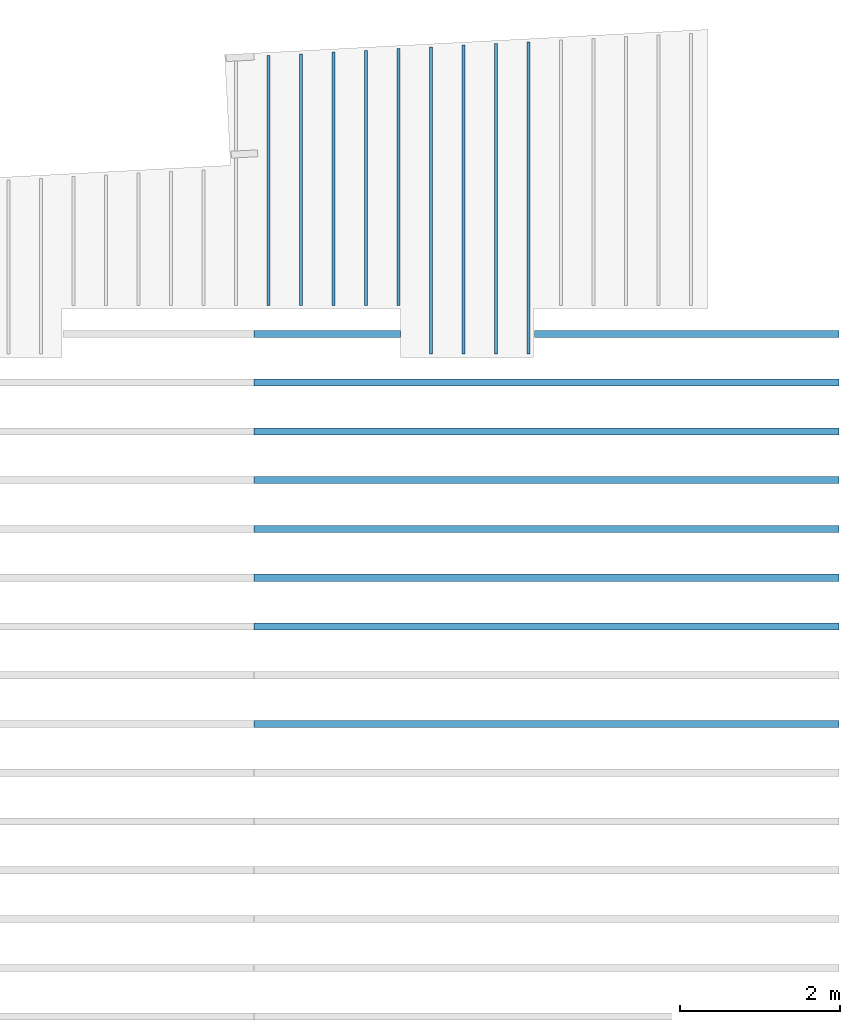
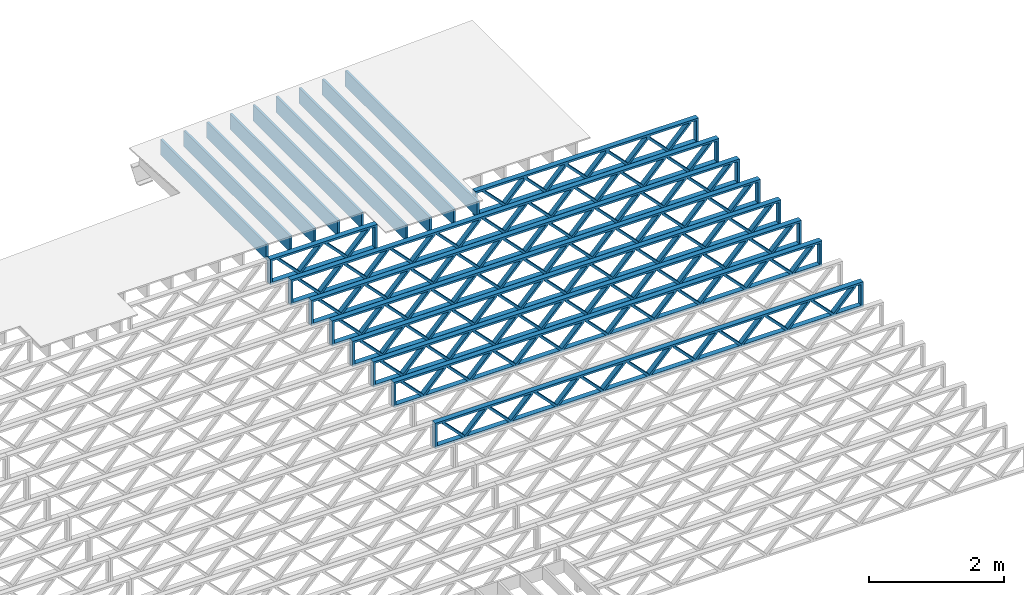
# One storey, part 11 of 12: 18 beams, 2 elements without a shape of their own.
"""IFC4 building model written with IfcOpenShell, lengths in feet."""

from ifc_helpers import new_model, entity, si_unit, converted_unit, derived_unit, direction, frame, frame_2d, origin, origin_2d_with_axis, place, context, subcontext, project, spatial, rectangle, extrude, source, transform, mapped, material, material_profile, profile_set, profile_usage, type_object, type_shapes, element, aggregate, save


model = new_model("IFC4")

# Units and contexts
model_context = context("Model", 3, precision=0.0001, world=origin(), true_north=direction((6.12303176911189e-17, 1.0)))
body_context = subcontext(model_context, "Body", "Model", "MODEL_VIEW")
ifc_project = project(units=[converted_unit("LENGTHUNIT", "FOOT", entity("IfcRatioMeasure", 0.3048), si_unit("LENGTHUNIT", "METRE"), dimensions=[1, 0, 0, 0, 0, 0, 0]), converted_unit("AREAUNIT", "SQUARE FOOT", entity("IfcRatioMeasure", 0.09290304), si_unit("AREAUNIT", "SQUARE_METRE"), dimensions=[2, 0, 0, 0, 0, 0, 0]), converted_unit("VOLUMEUNIT", "CUBIC FOOT", entity("IfcRatioMeasure", 0.028316846592), si_unit("VOLUMEUNIT", "CUBIC_METRE"), dimensions=[3, 0, 0, 0, 0, 0, 0]), converted_unit("PLANEANGLEUNIT", "DEGREE", entity("IfcRatioMeasure", 0.0174532925199433), si_unit("PLANEANGLEUNIT", "RADIAN"), dimensions=[0, 0, 0, 0, 0, 0, 0]), si_unit("MASSUNIT", "GRAM", prefix="KILO"), derived_unit("MASSDENSITYUNIT", [(si_unit("MASSUNIT", "GRAM", prefix="KILO"), 1), (si_unit("LENGTHUNIT", "METRE"), -3)]), derived_unit("MOMENTOFINERTIAUNIT", [(si_unit("LENGTHUNIT", "METRE"), 4)]), si_unit("TIMEUNIT", "SECOND"), si_unit("FREQUENCYUNIT", "HERTZ"), si_unit("THERMODYNAMICTEMPERATUREUNIT", "DEGREE_CELSIUS"), derived_unit("THERMALTRANSMITTANCEUNIT", [(si_unit("MASSUNIT", "GRAM", prefix="KILO"), 1), (si_unit("THERMODYNAMICTEMPERATUREUNIT", "KELVIN"), -1), (si_unit("TIMEUNIT", "SECOND"), -3)]), derived_unit("VOLUMETRICFLOWRATEUNIT", [(si_unit("LENGTHUNIT", "METRE"), 3), (si_unit("TIMEUNIT", "SECOND"), -1)]), si_unit("ELECTRICCURRENTUNIT", "AMPERE"), si_unit("ELECTRICVOLTAGEUNIT", "VOLT"), si_unit("POWERUNIT", "WATT"), si_unit("FORCEUNIT", "NEWTON"), si_unit("ILLUMINANCEUNIT", "LUX"), si_unit("LUMINOUSFLUXUNIT", "LUMEN"), si_unit("LUMINOUSINTENSITYUNIT", "CANDELA"), derived_unit("USERDEFINED", [(si_unit("MASSUNIT", "GRAM", prefix="KILO"), -1), (si_unit("LENGTHUNIT", "METRE"), -2), (si_unit("TIMEUNIT", "SECOND"), 3), (si_unit("LUMINOUSFLUXUNIT", "LUMEN"), 1)]), derived_unit("LINEARVELOCITYUNIT", [(si_unit("LENGTHUNIT", "METRE"), 1), (si_unit("TIMEUNIT", "SECOND"), -1)]), si_unit("PRESSUREUNIT", "PASCAL"), derived_unit("USERDEFINED", [(si_unit("LENGTHUNIT", "METRE"), -2), (si_unit("MASSUNIT", "GRAM", prefix="KILO"), 1), (si_unit("TIMEUNIT", "SECOND"), -2)]), derived_unit("LINEARFORCEUNIT", [(si_unit("MASSUNIT", "GRAM", prefix="KILO"), 1), (si_unit("LENGTHUNIT", "METRE"), 1), (si_unit("TIMEUNIT", "SECOND"), -2), (si_unit("LENGTHUNIT", "METRE"), -1)]), derived_unit("PLANARFORCEUNIT", [(si_unit("MASSUNIT", "GRAM", prefix="KILO"), 1), (si_unit("LENGTHUNIT", "METRE"), 1), (si_unit("TIMEUNIT", "SECOND"), -2), (si_unit("LENGTHUNIT", "METRE"), -2)])], contexts=[model_context])

# Site, building, storey
site_placement = place(None, origin())
site = spatial("IfcSite", under=ifc_project, at=site_placement, CompositionType="ELEMENT")
building_placement = place(site_placement, origin())
building = spatial("IfcBuilding", under=site, at=building_placement, CompositionType="ELEMENT")
storey_placement = place(building_placement, frame((0.0, 0.0, 21.46875)))
storey = spatial("IfcBuildingStorey", under=building, at=storey_placement, Name="3RD FLOOR", CompositionType="ELEMENT", Elevation=21.46875)

# Assembly, beams
assembly_1_placement = place(storey_placement, origin())
assembly_1 = element("IfcElementAssembly", 1, at=assembly_1_placement, inside=storey, Name="Structural Beam System:Structural Framing System", ObjectType="Structural Beam System:Structural Framing System", AssemblyPlace="NOTDEFINED", PredefinedType="BEAM_GRID")
ifc_material_1 = material(Name="WOOD TRUSS", Category="Materials")
ifc_material_profile_1 = material_profile(ifc_material_1, rectangle(XDim=1.73473973950632, YDim=0.125, at=frame_2d((-1.11022302462516e-16, 8.32667268468867e-17), x_axis=(1.0, 0.0))))
ifc_material_profile_2 = material_profile(ifc_material_1, rectangle(XDim=1.73473973950633, YDim=0.125, at=frame_2d((-1.11022302462516e-16, 8.32667268468867e-17), x_axis=(1.0, 0.0))))
ifc_material_profile_3 = material_profile(ifc_material_1, rectangle(XDim=1.73473973950632, YDim=0.125, at=frame_2d((-5.55111512312578e-17, 1.38777878078145e-16), x_axis=(1.0, 0.0))))
ifc_material_profile_4 = material_profile(ifc_material_1, rectangle(XDim=1.73473973950633, YDim=0.125, at=frame_2d((-1.11022302462516e-16, 8.32667268468867e-17), x_axis=(1.0, 0.0))))
ifc_material_profile_5 = material_profile(ifc_material_1, rectangle(XDim=1.73473973950632, YDim=0.125, at=frame_2d((-1.11022302462516e-16, 8.32667268468867e-17), x_axis=(1.0, 0.0))))
ifc_material_profile_6 = material_profile(ifc_material_1, rectangle(XDim=1.73473973950633, YDim=0.125, at=frame_2d((-2.77555756156289e-16, 3.05311331771918e-16), x_axis=(1.0, 0.0))))
ifc_material_profile_7 = material_profile(ifc_material_1, rectangle(XDim=1.73473973950632, YDim=0.124999999999999, at=frame_2d((-3.88578058618805e-16, -2.4980018054066e-16), x_axis=(1.0, 0.0))))
ifc_material_profile_8 = material_profile(ifc_material_1, rectangle(XDim=1.73473973950633, YDim=0.125, at=frame_2d((2.77555756156289e-16, -3.05311331771918e-16), x_axis=(1.0, 0.0))))
ifc_material_profile_9 = material_profile(ifc_material_1, rectangle(XDim=1.73473973950632, YDim=0.124999999999999, at=frame_2d((-1.11022302462516e-16, 8.32667268468867e-17), x_axis=(1.0, 0.0))))
ifc_material_profile_10 = material_profile(ifc_material_1, rectangle(XDim=1.73473973950633, YDim=0.125, at=origin_2d_with_axis()))
ifc_material_profile_11 = material_profile(ifc_material_1, rectangle(XDim=0.124999999999982, YDim=0.291666666666668, at=origin_2d_with_axis()))
ifc_material_profile_12 = material_profile(ifc_material_1, rectangle(XDim=0.124999999999932, YDim=0.291666666666664, at=origin_2d_with_axis()))
ifc_material_profile_13 = material_profile(ifc_material_1, rectangle(XDim=1.25000000000002, YDim=0.29166666666667, at=origin_2d_with_axis()))
ifc_material_profile_14 = material_profile(ifc_material_1, rectangle(XDim=1.25000000000004, YDim=0.291666666666667, at=origin_2d_with_axis()))
ifc_profile_set_1 = profile_set([ifc_material_profile_1, ifc_material_profile_2, ifc_material_profile_3, ifc_material_profile_4, ifc_material_profile_5, ifc_material_profile_6, ifc_material_profile_7, ifc_material_profile_8, ifc_material_profile_9, ifc_material_profile_10, ifc_material_profile_11, ifc_material_profile_12, ifc_material_profile_13, ifc_material_profile_14])
ifc_profile_usage_1 = profile_usage(ifc_profile_set_1, cardinal=8)
beam_type_1 = type_object("IfcBeamType", PredefinedType="BEAM", material=ifc_profile_set_1)
shared_shape_1 = source(origin(), body_context, "Body", "SweptSolid", [
    extrude(rectangle(XDim=1.73473973950632, YDim=0.125, at=frame_2d((-1.11022302462516e-16, 8.32667268468867e-17), x_axis=(1.0, 0.0))), frame((2.91681155651982, -0.145833333333334, 0.0), z_axis=(0.0, 1.0, 0.0), x_axis=(0.693383046997606, 0.0, 0.720569184836762)), (0.0, 0.0, 1.0), 0.291666666666667),
    extrude(rectangle(XDim=1.73473973950633, YDim=0.125, at=frame_2d((-1.11022302462516e-16, 8.32667268468867e-17), x_axis=(1.0, 0.0))), frame((1.66652568284655, -0.145833333333334, 0.0), z_axis=(0.0, 1.0, 0.0), x_axis=(0.69338304699761, 0.0, -0.720569184836758)), (0.0, 0.0, 1.0), 0.291666666666667),
    extrude(rectangle(XDim=1.73473973950632, YDim=0.125, at=frame_2d((-5.55111512312578e-17, 1.38777878078145e-16), x_axis=(1.0, 0.0))), frame((0.625142936836964, -0.145833333333334, 0.0), z_axis=(0.0, 1.0, 0.0), x_axis=(0.693383046997606, 0.0, 0.720569184836762)), (0.0, 0.0, 1.0), 0.291666666666667),
    extrude(rectangle(XDim=1.73473973950633, YDim=0.125, at=frame_2d((-1.11022302462516e-16, 8.32667268468867e-17), x_axis=(1.0, 0.0))), frame((-0.625142936836307, -0.145833333333334, 0.0), z_axis=(0.0, 1.0, 0.0), x_axis=(0.69338304699761, 0.0, -0.720569184836758)), (0.0, 0.0, 1.0), 0.291666666666667),
    extrude(rectangle(XDim=1.73473973950632, YDim=0.125, at=frame_2d((-1.11022302462516e-16, 8.32667268468867e-17), x_axis=(1.0, 0.0))), frame((-1.66652568284589, -0.145833333333334, 0.0), z_axis=(0.0, 1.0, 0.0), x_axis=(0.693383046997606, 0.0, 0.720569184836762)), (0.0, 0.0, 1.0), 0.291666666666667),
    extrude(rectangle(XDim=1.73473973950633, YDim=0.125, at=frame_2d((-2.77555756156289e-16, 3.05311331771918e-16), x_axis=(1.0, 0.0))), frame((-2.91681155651916, -0.145833333333334, 0.0), z_axis=(0.0, 1.0, 0.0), x_axis=(0.69338304699761, 0.0, -0.720569184836758)), (0.0, 0.0, 1.0), 0.291666666666667),
    extrude(rectangle(XDim=1.73473973950632, YDim=0.124999999999999, at=frame_2d((-3.88578058618805e-16, -2.4980018054066e-16), x_axis=(1.0, 0.0))), frame((5.20848017620267, -0.145833333333334, 0.0), z_axis=(0.0, 1.0, 0.0), x_axis=(0.693383046997607, 0.0, 0.720569184836761)), (0.0, 0.0, 1.0), 0.291666666666666),
    extrude(rectangle(XDim=1.73473973950633, YDim=0.125, at=frame_2d((2.77555756156289e-16, -3.05311331771918e-16), x_axis=(1.0, 0.0))), frame((3.9581943025294, -0.145833333333334, 0.0), z_axis=(0.0, 1.0, 0.0), x_axis=(0.69338304699761, 0.0, -0.720569184836758)), (0.0, 0.0, 1.0), 0.291666666666666),
    extrude(rectangle(XDim=1.73473973950632, YDim=0.124999999999999, at=frame_2d((-1.11022302462516e-16, 8.32667268468867e-17), x_axis=(1.0, 0.0))), frame((-3.95819430252874, -0.145833333333334, 0.0), z_axis=(0.0, 1.0, 0.0), x_axis=(0.693383046997606, 0.0, 0.720569184836762)), (0.0, 0.0, 1.0), 0.291666666666667),
    extrude(rectangle(XDim=1.73473973950633, YDim=0.125, at=origin_2d_with_axis()), frame((-5.20848017620202, -0.145833333333334, 0.0), z_axis=(0.0, 1.0, 0.0), x_axis=(0.69338304699761, 0.0, -0.720569184836758)), (0.0, 0.0, 1.0), 0.291666666666666),
    extrude(rectangle(XDim=0.124999999999982, YDim=0.291666666666668, at=origin_2d_with_axis()), frame((-6.25000390603229, 0.0, 0.687500000000054), z_axis=(1.0, 0.0, 0.0), x_axis=(0.0, 0.0, -1.0)), (0.0, 0.0, 1.0), 12.5000078120646),
    extrude(rectangle(XDim=0.124999999999932, YDim=0.291666666666664, at=origin_2d_with_axis()), frame((-6.25000390603208, 0.0, -0.687499999999984), z_axis=(1.0, 0.0, 0.0), x_axis=(0.0, 0.0, -1.0)), (0.0, 0.0, 1.0), 12.5000078120644),
    extrude(rectangle(XDim=1.25000000000002, YDim=0.29166666666667, at=origin_2d_with_axis()), frame((6.12500390603227, 0.0, 0.0), z_axis=(1.0, 0.0, 0.0), x_axis=(0.0, 0.0, -1.0)), (0.0, 0.0, 1.0), 0.12500000000002),
    extrude(rectangle(XDim=1.25000000000004, YDim=0.291666666666667, at=origin_2d_with_axis()), frame((-6.25000390603229, 0.0, 0.0), z_axis=(1.0, 0.0, 0.0), x_axis=(0.0, 0.0, -1.0)), (0.0, 0.0, 1.0), 0.125000000000023),
])
type_shapes(beam_type_1, [shared_shape_1])
beam_1_placement = place(assembly_1_placement, frame((-146.654823274369, 957.861934882651, -0.947916666657861), z_axis=(0.0, 0.0, 1.0), x_axis=(-1.0, 0.0, 0.0)))
beam_1 = element("IfcBeam", 2, at=beam_1_placement, type_object=beam_type_1, material=ifc_profile_usage_1, PredefinedType="BEAM", context=body_context, shape_type="MappedRepresentation", body=[
    mapped(shared_shape_1, transform((0.0, 0.0, 0.0), scale=1.0)),
])
ifc_profile_usage_2 = profile_usage(ifc_profile_set_1, cardinal=8)
beam_type_2 = type_object("IfcBeamType", PredefinedType="BEAM", material=ifc_profile_set_1)
shared_shape_2 = source(origin(), body_context, "Body", "SweptSolid", [
    extrude(rectangle(XDim=1.73473973950632, YDim=0.125, at=frame_2d((0.0, 1.66533453693773e-16), x_axis=(1.0, 0.0))), frame((1.95847576769603, -0.145833333333334, 0.0), z_axis=(0.0, 1.0, 0.0), x_axis=(0.693383046997606, 0.0, 0.720569184836762)), (0.0, 0.0, 1.0), 0.291666666666667),
    extrude(rectangle(XDim=1.73473973950633, YDim=0.125, at=frame_2d((-5.55111512312578e-17, 8.32667268468867e-17), x_axis=(1.0, 0.0))), frame((0.708189894022761, -0.145833333333334, 0.0), z_axis=(0.0, 1.0, 0.0), x_axis=(0.69338304699761, 0.0, -0.720569184836758)), (0.0, 0.0, 1.0), 0.291666666666667),
    extrude(rectangle(XDim=1.73473973950632, YDim=0.125, at=frame_2d((0.0, 1.66533453693773e-16), x_axis=(1.0, 0.0))), frame((-0.708189894022106, -0.145833333333334, 0.0), z_axis=(0.0, 1.0, 0.0), x_axis=(0.693383046997606, 0.0, 0.720569184836762)), (0.0, 0.0, 1.0), 0.291666666666667),
    extrude(rectangle(XDim=1.73473973950633, YDim=0.125, at=frame_2d((-2.22044604925031e-16, 2.22044604925031e-16), x_axis=(1.0, 0.0))), frame((-1.95847576769538, -0.145833333333334, 0.0), z_axis=(0.0, 1.0, 0.0), x_axis=(0.69338304699761, 0.0, -0.720569184836758)), (0.0, 0.0, 1.0), 0.291666666666666),
    extrude(rectangle(XDim=0.124999999999982, YDim=0.291666666666668, at=origin_2d_with_axis()), frame((-2.99999949752565, 0.0, 0.687500000000054), z_axis=(1.0, 0.0, 0.0), x_axis=(0.0, 0.0, -1.0)), (0.0, 0.0, 1.0), 5.9999989950513),
    extrude(rectangle(XDim=0.124999999999932, YDim=0.291666666666664, at=origin_2d_with_axis()), frame((-2.99999949752544, 0.0, -0.687499999999984), z_axis=(1.0, 0.0, 0.0), x_axis=(0.0, 0.0, -1.0)), (0.0, 0.0, 1.0), 5.99999899505109),
    extrude(rectangle(XDim=1.25000000000002, YDim=0.29166666666667, at=origin_2d_with_axis()), frame((2.87499949752563, 0.0, 0.0), z_axis=(1.0, 0.0, 0.0), x_axis=(0.0, 0.0, -1.0)), (0.0, 0.0, 1.0), 0.12500000000002),
    extrude(rectangle(XDim=1.25000000000004, YDim=0.291666666666667, at=origin_2d_with_axis()), frame((-2.99999949752565, 0.0, 0.0), z_axis=(1.0, 0.0, 0.0), x_axis=(0.0, 0.0, -1.0)), (0.0, 0.0, 1.0), 0.125000000000023),
])
type_shapes(beam_type_2, [shared_shape_2])
beam_2_placement = place(assembly_1_placement, frame((-161.40482765467, 957.861934882651, -0.947916666657854), z_axis=(0.0, 0.0, 1.0), x_axis=(-1.0, 0.0, 0.0)))
beam_2 = element("IfcBeam", 3, at=beam_2_placement, type_object=beam_type_2, material=ifc_profile_usage_2, PredefinedType="BEAM", context=body_context, shape_type="MappedRepresentation", body=[
    mapped(shared_shape_2, transform((0.0, 0.0, 0.0), scale=1.0)),
])
ifc_profile_usage_3 = profile_usage(ifc_profile_set_1, cardinal=8)
beam_type_3 = type_object("IfcBeamType", PredefinedType="BEAM", material=ifc_profile_set_1)
shared_shape_3 = source(origin(), body_context, "Body", "SweptSolid", [
    extrude(rectangle(XDim=1.73473973950632, YDim=0.124999999999999, at=frame_2d((5.55111512312578e-16, 7.21644966006352e-16), x_axis=(1.0, 0.0))), frame((8.37514585578398, -0.145833333333334, 0.0), z_axis=(0.0, 1.0, 0.0), x_axis=(0.693383046997606, 0.0, 0.720569184836762)), (0.0, 0.0, 1.0), 0.291666666666667),
    extrude(rectangle(XDim=1.73473973950633, YDim=0.125, at=origin_2d_with_axis()), frame((7.12485998211071, -0.145833333333334, 0.0), z_axis=(0.0, 1.0, 0.0), x_axis=(0.69338304699761, 0.0, -0.720569184836758)), (0.0, 0.0, 1.0), 0.291666666666666),
    extrude(rectangle(XDim=1.73473973950632, YDim=0.124999999999999, at=frame_2d((-1.11022302462516e-16, 8.32667268468867e-17), x_axis=(1.0, 0.0))), frame((5.79181154946831, -0.145833333333334, 0.0), z_axis=(0.0, 1.0, 0.0), x_axis=(0.693383046997606, 0.0, 0.720569184836762)), (0.0, 0.0, 1.0), 0.291666666666667),
    extrude(rectangle(XDim=1.73473973950633, YDim=0.125, at=origin_2d_with_axis()), frame((4.54152567579504, -0.145833333333334, 0.0), z_axis=(0.0, 1.0, 0.0), x_axis=(0.69338304699761, 0.0, -0.720569184836758)), (0.0, 0.0, 1.0), 0.291666666666666),
    extrude(rectangle(XDim=1.73473973950632, YDim=0.125, at=frame_2d((2.22044604925031e-16, 3.88578058618805e-16), x_axis=(1.0, 0.0))), frame((3.20847724315264, -0.145833333333334, 0.0), z_axis=(0.0, 1.0, 0.0), x_axis=(0.693383046997606, 0.0, 0.720569184836762)), (0.0, 0.0, 1.0), 0.291666666666667),
    extrude(rectangle(XDim=1.73473973950633, YDim=0.125, at=frame_2d((-1.11022302462516e-16, 8.32667268468867e-17), x_axis=(1.0, 0.0))), frame((1.95819136947937, -0.145833333333334, 0.0), z_axis=(0.0, 1.0, 0.0), x_axis=(0.69338304699761, 0.0, -0.720569184836758)), (0.0, 0.0, 1.0), 0.291666666666667),
    extrude(rectangle(XDim=1.73473973950632, YDim=0.125, at=frame_2d((-5.55111512312578e-17, 1.38777878078145e-16), x_axis=(1.0, 0.0))), frame((0.625142936836964, -0.145833333333334, 0.0), z_axis=(0.0, 1.0, 0.0), x_axis=(0.693383046997606, 0.0, 0.720569184836762)), (0.0, 0.0, 1.0), 0.291666666666667),
    extrude(rectangle(XDim=1.73473973950633, YDim=0.125, at=frame_2d((-1.11022302462516e-16, 8.32667268468867e-17), x_axis=(1.0, 0.0))), frame((-0.625142936836306, -0.145833333333334, 0.0), z_axis=(0.0, 1.0, 0.0), x_axis=(0.69338304699761, 0.0, -0.720569184836758)), (0.0, 0.0, 1.0), 0.291666666666667),
    extrude(rectangle(XDim=1.73473973950632, YDim=0.125, at=frame_2d((-1.11022302462516e-16, 8.32667268468867e-17), x_axis=(1.0, 0.0))), frame((-1.95819136947871, -0.145833333333334, 0.0), z_axis=(0.0, 1.0, 0.0), x_axis=(0.693383046997606, 0.0, 0.720569184836762)), (0.0, 0.0, 1.0), 0.291666666666667),
    extrude(rectangle(XDim=1.73473973950633, YDim=0.125, at=origin_2d_with_axis()), frame((-3.20847724315198, -0.145833333333334, 0.0), z_axis=(0.0, 1.0, 0.0), x_axis=(0.69338304699761, 0.0, -0.720569184836758)), (0.0, 0.0, 1.0), 0.291666666666667),
    extrude(rectangle(XDim=1.73473973950632, YDim=0.124999999999999, at=frame_2d((-1.11022302462516e-16, 8.32667268468867e-17), x_axis=(1.0, 0.0))), frame((-4.54152567579438, -0.145833333333334, 0.0), z_axis=(0.0, 1.0, 0.0), x_axis=(0.693383046997606, 0.0, 0.720569184836762)), (0.0, 0.0, 1.0), 0.291666666666667),
    extrude(rectangle(XDim=1.73473973950633, YDim=0.125, at=origin_2d_with_axis()), frame((-5.79181154946765, -0.145833333333334, 0.0), z_axis=(0.0, 1.0, 0.0), x_axis=(0.69338304699761, 0.0, -0.720569184836758)), (0.0, 0.0, 1.0), 0.291666666666666),
    extrude(rectangle(XDim=1.73473973950632, YDim=0.124999999999999, at=frame_2d((-1.11022302462516e-16, 8.32667268468867e-17), x_axis=(1.0, 0.0))), frame((-7.12485998211005, -0.145833333333334, 0.0), z_axis=(0.0, 1.0, 0.0), x_axis=(0.693383046997606, 0.0, 0.720569184836762)), (0.0, 0.0, 1.0), 0.291666666666667),
    extrude(rectangle(XDim=1.73473973950633, YDim=0.125, at=frame_2d((-2.77555756156289e-16, 3.05311331771918e-16), x_axis=(1.0, 0.0))), frame((-8.37514585578332, -0.145833333333334, 0.0), z_axis=(0.0, 1.0, 0.0), x_axis=(0.69338304699761, 0.0, -0.720569184836758)), (0.0, 0.0, 1.0), 0.291666666666666),
    extrude(rectangle(XDim=1.73473973950632, YDim=0.125, at=frame_2d((-7.21644966006352e-16, -5.55111512312578e-16), x_axis=(1.0, 0.0))), frame((10.9584801620997, -0.145833333333334, 0.0), z_axis=(0.0, 1.0, 0.0), x_axis=(0.693383046997606, 0.0, 0.720569184836762)), (0.0, 0.0, 1.0), 0.291666666666667),
    extrude(rectangle(XDim=1.73473973950633, YDim=0.125, at=origin_2d_with_axis()), frame((9.70819428842638, -0.145833333333334, 0.0), z_axis=(0.0, 1.0, 0.0), x_axis=(0.69338304699761, 0.0, -0.720569184836758)), (0.0, 0.0, 1.0), 0.291666666666666),
    extrude(rectangle(XDim=1.73473973950632, YDim=0.125, at=frame_2d((-5.55111512312578e-17, 8.32667268468867e-17), x_axis=(1.0, 0.0))), frame((-9.70819428842572, -0.145833333333334, 0.0), z_axis=(0.0, 1.0, 0.0), x_axis=(0.693383046997606, 0.0, 0.720569184836762)), (0.0, 0.0, 1.0), 0.291666666666667),
    extrude(rectangle(XDim=1.73473973950633, YDim=0.125, at=origin_2d_with_axis()), frame((-10.958480162099, -0.145833333333334, 0.0), z_axis=(0.0, 1.0, 0.0), x_axis=(0.69338304699761, 0.0, -0.720569184836758)), (0.0, 0.0, 1.0), 0.291666666666666),
    extrude(rectangle(XDim=0.124999999999982, YDim=0.291666666666668, at=origin_2d_with_axis()), frame((-12.0000038919293, 0.0, 0.687500000000054), z_axis=(1.0, 0.0, 0.0), x_axis=(0.0, 0.0, -1.0)), (0.0, 0.0, 1.0), 24.0000077838585),
    extrude(rectangle(XDim=0.124999999999932, YDim=0.291666666666664, at=origin_2d_with_axis()), frame((-12.0000038919291, 0.0, -0.687499999999984), z_axis=(1.0, 0.0, 0.0), x_axis=(0.0, 0.0, -1.0)), (0.0, 0.0, 1.0), 24.0000077838583),
    extrude(rectangle(XDim=1.25000000000002, YDim=0.29166666666667, at=origin_2d_with_axis()), frame((11.8750038919292, 0.0, 0.0), z_axis=(1.0, 0.0, 0.0), x_axis=(0.0, 0.0, -1.0)), (0.0, 0.0, 1.0), 0.12500000000002),
    extrude(rectangle(XDim=1.25000000000004, YDim=0.291666666666667, at=origin_2d_with_axis()), frame((-12.0000038919293, 0.0, 0.0), z_axis=(1.0, 0.0, 0.0), x_axis=(0.0, 0.0, -1.0)), (0.0, 0.0, 1.0), 0.125000000000023),
])
type_shapes(beam_type_3, [shared_shape_3])
beam_3_placement = place(assembly_1_placement, frame((-152.404823260266, 955.861934882651, -0.947916666657864), z_axis=(0.0, 0.0, 1.0), x_axis=(-1.0, 0.0, 0.0)))
beam_3 = element("IfcBeam", 4, at=beam_3_placement, type_object=beam_type_3, material=ifc_profile_usage_3, PredefinedType="BEAM", context=body_context, shape_type="MappedRepresentation", body=[
    mapped(shared_shape_3, transform((0.0, 0.0, 0.0), scale=1.0)),
])
ifc_profile_usage_4 = profile_usage(ifc_profile_set_1, cardinal=8)
beam_4_placement = place(assembly_1_placement, frame((-152.404823260266, 953.861934882651, -0.947916666657864), z_axis=(0.0, 0.0, 1.0), x_axis=(-1.0, 0.0, 0.0)))
beam_4 = element("IfcBeam", 5, at=beam_4_placement, type_object=beam_type_3, material=ifc_profile_usage_4, PredefinedType="BEAM", context=body_context, shape_type="MappedRepresentation", body=[
    mapped(shared_shape_3, transform((0.0, 0.0, 0.0), scale=1.0)),
])
ifc_profile_usage_5 = profile_usage(ifc_profile_set_1, cardinal=8)
beam_5_placement = place(assembly_1_placement, frame((-152.404823260266, 951.861934882651, -0.947916666657864), z_axis=(0.0, 0.0, 1.0), x_axis=(-1.0, 0.0, 0.0)))
beam_5 = element("IfcBeam", 6, at=beam_5_placement, type_object=beam_type_3, material=ifc_profile_usage_5, PredefinedType="BEAM", context=body_context, shape_type="MappedRepresentation", body=[
    mapped(shared_shape_3, transform((0.0, 0.0, 0.0), scale=1.0)),
])
ifc_profile_usage_6 = profile_usage(ifc_profile_set_1, cardinal=8)
beam_6_placement = place(assembly_1_placement, frame((-152.404823260266, 949.861934882651, -0.947916666657864), z_axis=(0.0, 0.0, 1.0), x_axis=(-1.0, 0.0, 0.0)))
beam_6 = element("IfcBeam", 7, at=beam_6_placement, type_object=beam_type_3, material=ifc_profile_usage_6, PredefinedType="BEAM", context=body_context, shape_type="MappedRepresentation", body=[
    mapped(shared_shape_3, transform((0.0, 0.0, 0.0), scale=1.0)),
])
ifc_profile_usage_7 = profile_usage(ifc_profile_set_1, cardinal=8)
beam_7_placement = place(assembly_1_placement, frame((-152.404823260266, 947.861934882651, -0.947916666657864), z_axis=(0.0, 0.0, 1.0), x_axis=(-1.0, 0.0, 0.0)))
beam_7 = element("IfcBeam", 8, at=beam_7_placement, type_object=beam_type_3, material=ifc_profile_usage_7, PredefinedType="BEAM", context=body_context, shape_type="MappedRepresentation", body=[
    mapped(shared_shape_3, transform((0.0, 0.0, 0.0), scale=1.0)),
])
ifc_profile_usage_8 = profile_usage(ifc_profile_set_1, cardinal=8)
beam_8_placement = place(assembly_1_placement, frame((-152.404823260266, 945.861934882651, -0.947916666657864), z_axis=(0.0, 0.0, 1.0), x_axis=(-1.0, 0.0, 0.0)))
beam_8 = element("IfcBeam", 9, at=beam_8_placement, type_object=beam_type_3, material=ifc_profile_usage_8, PredefinedType="BEAM", context=body_context, shape_type="MappedRepresentation", body=[
    mapped(shared_shape_3, transform((0.0, 0.0, 0.0), scale=1.0)),
])
ifc_profile_usage_9 = profile_usage(ifc_profile_set_1, cardinal=8)
beam_9_placement = place(assembly_1_placement, frame((-152.404823260266, 941.861934882651, -0.947916666657864), z_axis=(0.0, 0.0, 1.0), x_axis=(-1.0, 0.0, 0.0)))
beam_9 = element("IfcBeam", 10, at=beam_9_placement, type_object=beam_type_3, material=ifc_profile_usage_9, PredefinedType="BEAM", context=body_context, shape_type="MappedRepresentation", body=[
    mapped(shared_shape_3, transform((0.0, 0.0, 0.0), scale=1.0)),
])
aggregate(assembly_1, [beam_1, beam_2, beam_3, beam_4, beam_5, beam_6, beam_7, beam_8, beam_9])

assembly_2_placement = place(storey_placement, origin())
assembly_2 = element("IfcElementAssembly", 11, at=assembly_2_placement, inside=storey, Name="Structural Beam System:Structural Framing System", ObjectType="Structural Beam System:Structural Framing System", AssemblyPlace="NOTDEFINED", PredefinedType="BEAM_GRID")
ifc_material_2 = material(Category="Materials")
ifc_material_profile_15 = material_profile(ifc_material_2, rectangle(XDim=0.9375, YDim=0.125000000000011, at=origin_2d_with_axis()))
ifc_profile_set_2 = profile_set([ifc_material_profile_15])
ifc_profile_usage_10 = profile_usage(ifc_profile_set_2, cardinal=8)
beam_type_4 = type_object("IfcBeamType", PredefinedType="BEAM", material=ifc_profile_set_2)
shared_shape_4 = source(origin(), body_context, "Body", "SweptSolid", [
    extrude(rectangle(XDim=0.9375, YDim=0.125000000000011, at=origin_2d_with_axis()), frame((-5.1262521090531, 0.0, 0.0), z_axis=(1.0, 0.0, 0.0), x_axis=(0.0, 0.0, -1.0)), (0.0, 0.0, 1.0), 10.2525042181062),
])
type_shapes(beam_type_4, [shared_shape_4])
beam_10_placement = place(assembly_2_placement, frame((-163.810956052701, 964.154851685055, -0.729166666666714), z_axis=(0.0, 0.0, 1.0), x_axis=(0.0, 1.0, 0.0)))
beam_10 = element("IfcBeam", 12, at=beam_10_placement, type_object=beam_type_4, material=ifc_profile_usage_10, PredefinedType="BEAM", context=body_context, shape_type="MappedRepresentation", body=[
    mapped(shared_shape_4, transform((0.0, 0.0, 0.0), scale=1.0)),
])
ifc_profile_usage_11 = profile_usage(ifc_profile_set_2, cardinal=8)
beam_type_5 = type_object("IfcBeamType", PredefinedType="BEAM", material=ifc_profile_set_2)
shared_shape_5 = source(origin(), body_context, "Body", "SweptSolid", [
    extrude(rectangle(XDim=0.9375, YDim=0.125000000000011, at=origin_2d_with_axis()), frame((-5.16119046107383, 0.0, 0.0), z_axis=(1.0, 0.0, 0.0), x_axis=(0.0, 0.0, -1.0)), (0.0, 0.0, 1.0), 10.3223809221477),
])
type_shapes(beam_type_5, [shared_shape_5])
beam_11_placement = place(assembly_2_placement, frame((-162.477622719368, 964.189790372079, -0.729166666666714), z_axis=(0.0, 0.0, 1.0), x_axis=(0.0, 1.0, 0.0)))
beam_11 = element("IfcBeam", 13, at=beam_11_placement, type_object=beam_type_5, material=ifc_profile_usage_11, PredefinedType="BEAM", context=body_context, shape_type="MappedRepresentation", body=[
    mapped(shared_shape_5, transform((0.0, 0.0, 0.0), scale=1.0)),
])
ifc_profile_usage_12 = profile_usage(ifc_profile_set_2, cardinal=8)
beam_type_6 = type_object("IfcBeamType", PredefinedType="BEAM", material=ifc_profile_set_2)
shared_shape_6 = source(origin(), body_context, "Body", "SweptSolid", [
    extrude(rectangle(XDim=0.9375, YDim=0.125000000000011, at=origin_2d_with_axis()), frame((-5.19612881309462, 0.0, 0.0), z_axis=(1.0, 0.0, 0.0), x_axis=(0.0, 0.0, -1.0)), (0.0, 0.0, 1.0), 10.3922576261892),
])
type_shapes(beam_type_6, [shared_shape_6])
beam_12_placement = place(assembly_2_placement, frame((-161.144289386034, 964.224729059102, -0.729166666666714), z_axis=(0.0, 0.0, 1.0), x_axis=(0.0, 1.0, 0.0)))
beam_12 = element("IfcBeam", 14, at=beam_12_placement, type_object=beam_type_6, material=ifc_profile_usage_12, PredefinedType="BEAM", context=body_context, shape_type="MappedRepresentation", body=[
    mapped(shared_shape_6, transform((0.0, 0.0, 0.0), scale=1.0)),
])
ifc_profile_usage_13 = profile_usage(ifc_profile_set_2, cardinal=8)
beam_type_7 = type_object("IfcBeamType", PredefinedType="BEAM", material=ifc_profile_set_2)
shared_shape_7 = source(origin(), body_context, "Body", "SweptSolid", [
    extrude(rectangle(XDim=0.9375, YDim=0.125000000000011, at=origin_2d_with_axis()), frame((-5.23106716511541, 0.0, 0.0), z_axis=(1.0, 0.0, 0.0), x_axis=(0.0, 0.0, -1.0)), (0.0, 0.0, 1.0), 10.4621343302308),
])
type_shapes(beam_type_7, [shared_shape_7])
beam_13_placement = place(assembly_2_placement, frame((-159.810956052701, 964.259667746125, -0.729166666666714), z_axis=(0.0, 0.0, 1.0), x_axis=(0.0, 1.0, 0.0)))
beam_13 = element("IfcBeam", 15, at=beam_13_placement, type_object=beam_type_7, material=ifc_profile_usage_13, PredefinedType="BEAM", context=body_context, shape_type="MappedRepresentation", body=[
    mapped(shared_shape_7, transform((0.0, 0.0, 0.0), scale=1.0)),
])
ifc_profile_usage_14 = profile_usage(ifc_profile_set_2, cardinal=8)
beam_type_8 = type_object("IfcBeamType", PredefinedType="BEAM", material=ifc_profile_set_2)
shared_shape_8 = source(origin(), body_context, "Body", "SweptSolid", [
    extrude(rectangle(XDim=0.9375, YDim=0.125000000000011, at=origin_2d_with_axis()), frame((-5.26600551713619, 0.0, 0.0), z_axis=(1.0, 0.0, 0.0), x_axis=(0.0, 0.0, -1.0)), (0.0, 0.0, 1.0), 10.5320110342724),
])
type_shapes(beam_type_8, [shared_shape_8])
beam_14_placement = place(assembly_2_placement, frame((-158.477622719368, 964.294606433148, -0.729166666666714), z_axis=(0.0, 0.0, 1.0), x_axis=(0.0, 1.0, 0.0)))
beam_14 = element("IfcBeam", 16, at=beam_14_placement, type_object=beam_type_8, material=ifc_profile_usage_14, PredefinedType="BEAM", context=body_context, shape_type="MappedRepresentation", body=[
    mapped(shared_shape_8, transform((0.0, 0.0, 0.0), scale=1.0)),
])
ifc_profile_usage_15 = profile_usage(ifc_profile_set_2, cardinal=8)
beam_type_9 = type_object("IfcBeamType", PredefinedType="BEAM", material=ifc_profile_set_2)
shared_shape_9 = source(origin(), body_context, "Body", "SweptSolid", [
    extrude(rectangle(XDim=0.9375, YDim=0.125000000000011, at=origin_2d_with_axis()), frame((-6.30094542235764, 0.0, 0.0), z_axis=(1.0, 0.0, 0.0), x_axis=(0.0, 0.0, -1.0)), (0.0, 0.0, 1.0), 12.6018908447153),
])
type_shapes(beam_type_9, [shared_shape_9])
beam_15_placement = place(assembly_2_placement, frame((-157.144289386034, 963.329543566971, -0.729166666666714), z_axis=(0.0, 0.0, 1.0), x_axis=(0.0, 1.0, 0.0)))
beam_15 = element("IfcBeam", 17, at=beam_15_placement, type_object=beam_type_9, material=ifc_profile_usage_15, PredefinedType="BEAM", context=body_context, shape_type="MappedRepresentation", body=[
    mapped(shared_shape_9, transform((0.0, 0.0, 0.0), scale=1.0)),
])
ifc_profile_usage_16 = profile_usage(ifc_profile_set_2, cardinal=8)
beam_type_10 = type_object("IfcBeamType", PredefinedType="BEAM", material=ifc_profile_set_2)
shared_shape_10 = source(origin(), body_context, "Body", "SweptSolid", [
    extrude(rectangle(XDim=0.9375, YDim=0.125000000000011, at=origin_2d_with_axis()), frame((-6.33588394187967, 0.0, 0.0), z_axis=(1.0, 0.0, 0.0), x_axis=(0.0, 0.0, -1.0)), (0.0, 0.0, 1.0), 12.6717678837593),
])
type_shapes(beam_type_10, [shared_shape_10])
beam_16_placement = place(assembly_2_placement, frame((-155.810956052701, 963.364482086493, -0.729166666666714), z_axis=(0.0, 0.0, 1.0), x_axis=(0.0, 1.0, 0.0)))
beam_16 = element("IfcBeam", 18, at=beam_16_placement, type_object=beam_type_10, material=ifc_profile_usage_16, PredefinedType="BEAM", context=body_context, shape_type="MappedRepresentation", body=[
    mapped(shared_shape_10, transform((0.0, 0.0, 0.0), scale=1.0)),
])
ifc_profile_usage_17 = profile_usage(ifc_profile_set_2, cardinal=8)
beam_type_11 = type_object("IfcBeamType", PredefinedType="BEAM", material=ifc_profile_set_2)
shared_shape_11 = source(origin(), body_context, "Body", "SweptSolid", [
    extrude(rectangle(XDim=0.9375, YDim=0.125000000000011, at=origin_2d_with_axis()), frame((-6.3708224614017, 0.0, 0.0), z_axis=(1.0, 0.0, 0.0), x_axis=(0.0, 0.0, -1.0)), (0.0, 0.0, 1.0), 12.7416449228034),
])
type_shapes(beam_type_11, [shared_shape_11])
beam_17_placement = place(assembly_2_placement, frame((-154.477622719368, 963.399420606015, -0.729166666666714), z_axis=(0.0, 0.0, 1.0), x_axis=(0.0, 1.0, 0.0)))
beam_17 = element("IfcBeam", 19, at=beam_17_placement, type_object=beam_type_11, material=ifc_profile_usage_17, PredefinedType="BEAM", context=body_context, shape_type="MappedRepresentation", body=[
    mapped(shared_shape_11, transform((0.0, 0.0, 0.0), scale=1.0)),
])
ifc_profile_usage_18 = profile_usage(ifc_profile_set_2, cardinal=8)
beam_type_12 = type_object("IfcBeamType", PredefinedType="BEAM", material=ifc_profile_set_2)
shared_shape_12 = source(origin(), body_context, "Body", "SweptSolid", [
    extrude(rectangle(XDim=0.9375, YDim=0.125000000000011, at=origin_2d_with_axis()), frame((-6.40576098092373, 0.0, 0.0), z_axis=(1.0, 0.0, 0.0), x_axis=(0.0, 0.0, -1.0)), (0.0, 0.0, 1.0), 12.8115219618475),
])
type_shapes(beam_type_12, [shared_shape_12])
beam_18_placement = place(assembly_2_placement, frame((-153.144289386034, 963.434359125537, -0.729166666666714), z_axis=(0.0, 0.0, 1.0), x_axis=(0.0, 1.0, 0.0)))
beam_18 = element("IfcBeam", 20, at=beam_18_placement, type_object=beam_type_12, material=ifc_profile_usage_18, PredefinedType="BEAM", context=body_context, shape_type="MappedRepresentation", body=[
    mapped(shared_shape_12, transform((0.0, 0.0, 0.0), scale=1.0)),
])
aggregate(assembly_2, [beam_10, beam_11, beam_12, beam_13, beam_14, beam_15, beam_16, beam_17, beam_18])

save(model, "model.ifc")
